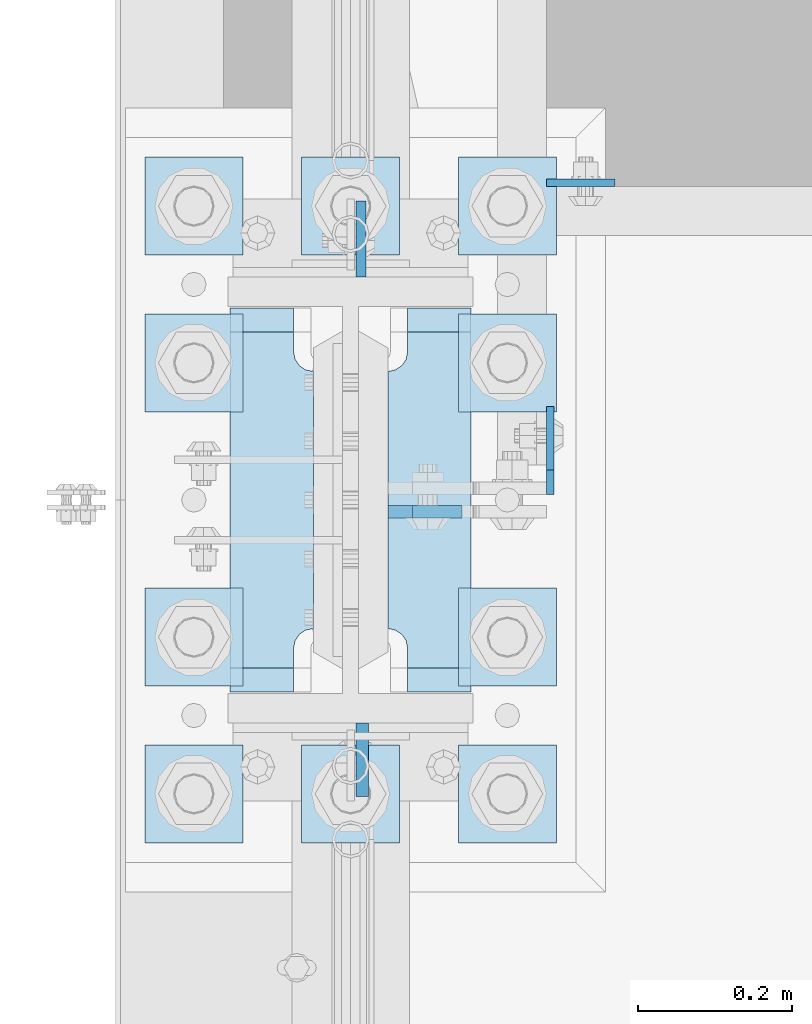
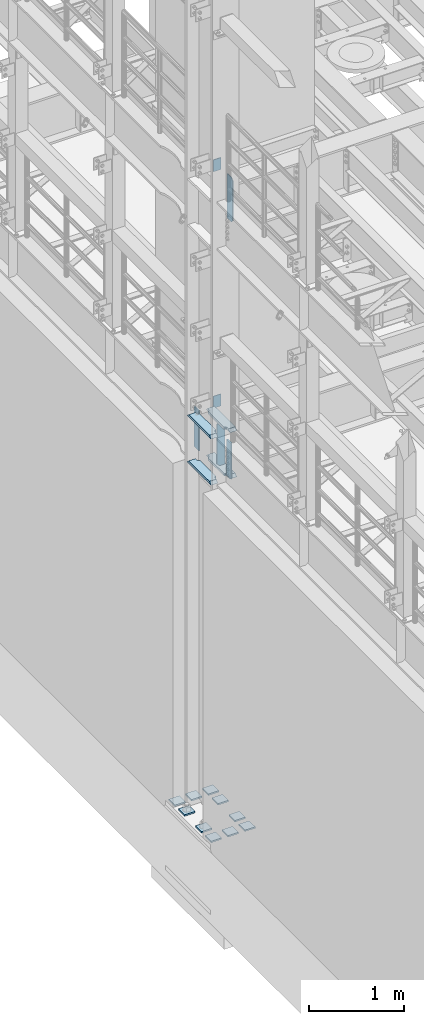
# One storey, part 1553 of 1876: 20 plates, 5 elements without a shape of their own.
"""IFC2X3 building model written with IfcOpenShell, lengths in millimetres."""

from ifc_helpers import new_model, si_unit, frame, origin_with_axes, place, context, subcontext, project, spatial, faceted_brep, material, type_object, element, aggregate, save


model = new_model("IFC2X3")

# Units and contexts
model_context = context("Model", 3, precision=1e-05, world=origin_with_axes())
body_context = subcontext(model_context, "Body", "Model", "MODEL_VIEW")
ifc_project = project(units=[si_unit("LENGTHUNIT", "METRE", prefix="MILLI"), si_unit("AREAUNIT", "SQUARE_METRE"), si_unit("VOLUMEUNIT", "CUBIC_METRE"), si_unit("MASSUNIT", "GRAM", prefix="KILO"), si_unit("TIMEUNIT", "SECOND"), si_unit("PLANEANGLEUNIT", "RADIAN"), si_unit("SOLIDANGLEUNIT", "STERADIAN"), si_unit("THERMODYNAMICTEMPERATUREUNIT", "DEGREE_CELSIUS"), si_unit("LUMINOUSINTENSITYUNIT", "LUMEN")], contexts=[model_context])

# Site, building, storey
site_placement = place(None, origin_with_axes())
site = spatial("IfcSite", under=ifc_project, at=site_placement, CompositionType="ELEMENT")
building_placement = place(site_placement, origin_with_axes())
building = spatial("IfcBuilding", under=site, at=building_placement, Name="Undefined", CompositionType="ELEMENT")
storey_placement = place(building_placement, origin_with_axes())
storey = spatial("IfcBuildingStorey", under=building, at=storey_placement, Name="Undefined", CompositionType="ELEMENT", Elevation=0.0)

# Assembly, plate
assembly_1_placement = place(storey_placement, origin_with_axes())
assembly_1 = element("IfcElementAssembly", 1, at=assembly_1_placement, inside=storey, Name="BEAM", AssemblyPlace="NOTDEFINED", PredefinedType="RIGID_FRAME")
ifc_material_1 = material(Name="STEEL/A36")
plate_type_1 = type_object("IfcPlateType", PredefinedType="NOTDEFINED")
plate_1_placement = place(assembly_1_placement, frame((254.0, 1935.1625, 8128.0), z_axis=(1.0, 0.0, 0.0), x_axis=(0.0, 0.0, -1.0)))
plate_1 = element("IfcPlate", 2, at=plate_1_placement, type_object=plate_type_1, material=ifc_material_1, Name="PLATE", context=body_context, shape_type="Brep", body=[
    faceted_brep([(0.0, -4.76249999999982, 0.0), (0.0, -4.76249999999982, 88.9000015258789), (0.0, 4.76249999999982, 88.9000015258789), (0.0, 4.76249999999982, 0.0), (152.399993896484, -4.76249999999982, 88.9000015258789), (152.399993896484, 4.76249999999982, 88.9000015258789), (152.399993896484, -4.76249999999982, 0.0), (152.399993896484, 4.76249999999982, 0.0)], [[[0, 1, 2, 3]], [[1, 4, 5, 2]], [[4, 6, 7, 5]], [[6, 0, 3, 7]], [[5, 7, 3, 2]], [[6, 4, 1, 0]]]),
])
aggregate(assembly_1, [plate_1])

assembly_2_placement = place(storey_placement, origin_with_axes())
assembly_2 = element("IfcElementAssembly", 3, at=assembly_2_placement, inside=storey, Name="BEAM", AssemblyPlace="NOTDEFINED", PredefinedType="RIGID_FRAME")
plate_2_placement = place(assembly_2_placement, frame((254.0, 1935.1625, 5105.4), z_axis=(1.0, 0.0, 0.0), x_axis=(0.0, 0.0, -1.0)))
plate_2 = element("IfcPlate", 4, at=plate_2_placement, type_object=plate_type_1, material=ifc_material_1, Name="PLATE", context=body_context, shape_type="Brep", body=[
    faceted_brep([(0.0, -4.76249999999982, 0.0), (0.0, -4.76249999999982, 88.9000015258789), (0.0, 4.76249999999982, 88.9000015258789), (0.0, 4.76249999999982, 0.0), (152.399993896484, -4.76249999999982, 88.9000015258789), (152.399993896484, 4.76249999999982, 88.9000015258789), (152.399993896484, -4.76249999999982, 0.0), (152.399993896484, 4.76249999999982, 0.0)], [[[0, 1, 2, 3]], [[1, 4, 5, 2]], [[4, 6, 7, 5]], [[6, 0, 3, 7]], [[5, 7, 3, 2]], [[6, 4, 1, 0]]]),
])
aggregate(assembly_2, [plate_2])

assembly_3_placement = place(storey_placement, origin_with_axes())
assembly_3 = element("IfcElementAssembly", 5, at=assembly_3_placement, inside=storey, Name="COLUMN", AssemblyPlace="NOTDEFINED", PredefinedType="RIGID_FRAME")
ifc_material_2 = material(Name="STEEL/A572-50")
plate_type_2 = type_object("IfcPlateType", PredefinedType="NOTDEFINED")
plate_3_placement = place(assembly_3_placement, frame((13.493000125885, 1812.925, 5076.825), z_axis=(0.0, 1.0, 0.0), x_axis=(0.0, 0.0, -1.0)))
plate_3 = element("IfcPlate", 6, at=plate_3_placement, type_object=plate_type_2, material=ifc_material_2, Name="PLATE", context=body_context, shape_type="Brep", body=[
    faceted_brep([(0.0, -6.35000000000036, 0.0), (0.0, -6.34999999999991, 98.4250030517578), (0.0, 6.34999999999991, 98.4250030517578), (0.0, 6.35000000000036, 0.0), (514.349975585938, -6.35000000000036, 98.4250030517578), (514.349975585938, 6.35000000000036, 98.4250030517578), (514.349975585938, -6.35000000000036, 0.0), (514.349975585938, 6.35000000000036, 0.0)], [[[0, 1, 2, 3]], [[1, 4, 5, 2]], [[4, 6, 7, 5]], [[6, 0, 3, 7]], [[5, 7, 3, 2]], [[6, 4, 1, 0]]]),
])

assembly_4_placement = place(storey_placement, origin_with_axes())
assembly_4 = element("IfcElementAssembly", 7, at=assembly_4_placement, inside=storey, Name="BEAM", AssemblyPlace="NOTDEFINED", PredefinedType="RIGID_FRAME")
plate_type_3 = type_object("IfcPlateType", PredefinedType="NOTDEFINED")
plate_4_placement = place(assembly_4_placement, frame((258.762999916077, 1531.14375, 7558.0875), z_axis=(0.0, 0.0, 1.0), x_axis=(0.0, 1.0, 0.0)))
plate_4 = element("IfcPlate", 8, at=plate_4_placement, type_object=plate_type_3, material=ifc_material_1, Name="PLATE", context=body_context, shape_type="Brep", body=[
    faceted_brep([(-9.76996261670138e-14, -4.76250000000073, 31.75), (0.0, -4.76249999999999, 538.162475585938), (0.0, 4.76249999999999, 538.162475585938), (-9.76996261670138e-14, 4.76250000000073, 31.75), (31.75, -4.76249999999999, 569.912475585938), (31.75, 4.76249999999999, 569.912475585938), (114.300003051758, -4.76249999999999, 569.912475585938), (114.300003051758, 4.76249999999999, 569.912475585938), (114.300003051758, -4.76249999999999, 0.0), (114.300003051758, 4.76249999999999, 0.0), (31.75, -4.76250000000073, 0.0), (31.75, 4.76250000000073, 0.0)], [[[0, 1, 2, 3]], [[1, 4, 5, 2]], [[4, 6, 7, 5]], [[6, 8, 9, 7]], [[8, 10, 11, 9]], [[10, 0, 3, 11]], [[5, 7, 9, 11, 3, 2]], [[10, 8, 6, 4, 1, 0]]]),
])
aggregate(assembly_4, [plate_4])

# Plate
plate_type_4 = type_object("IfcPlateType", PredefinedType="NOTDEFINED")
plate_5_placement = place(assembly_3_placement, frame((48.4187500000005, 1508.91949987411, 5099.05), z_axis=(1.0, 0.0, 0.0), x_axis=(0.0, 0.0, -1.0)))
plate_5 = element("IfcPlate", 9, at=plate_5_placement, type_object=plate_type_4, material=ifc_material_1, Name="PLATE", context=body_context, shape_type="Brep", body=[
    faceted_brep([(0.0, -7.93749999999998, 31.75), (0.0, -7.9375, 96.0437469482422), (0.0, 7.9375, 96.0437469482422), (0.0, 7.93749999999999, 31.75), (558.799987792969, -7.9375, 96.0437469482422), (558.799987792969, 7.9375, 96.0437469482422), (558.799987792969, -7.93749999999998, 31.75), (558.799987792969, 7.93749999999999, 31.75), (527.049987792969, -7.93749999999998, 0.0), (527.049987792969, 7.93749999999999, 0.0), (31.75, -7.93749999999998, 0.0), (31.75, 7.93749999999999, 0.0)], [[[0, 1, 2, 3]], [[1, 4, 5, 2]], [[4, 6, 7, 5]], [[6, 8, 9, 7]], [[8, 10, 11, 9]], [[10, 0, 3, 11]], [[5, 7, 9, 11, 3, 2]], [[10, 8, 6, 4, 1, 0]]]),
])

plate_6_placement = place(assembly_3_placement, frame((15.080500125885, 1235.075, 5067.3), z_axis=(0.0, -1.0, 0.0), x_axis=(0.0, 0.0, -1.0)))
plate_6 = element("IfcPlate", 10, at=plate_6_placement, type_object=plate_type_4, material=ifc_material_1, Name="PLATE", context=body_context, shape_type="Brep", body=[
    faceted_brep([(0.0, -7.9375, 0.0), (0.0, -7.9375, 95.25), (0.0, 7.9375, 95.25), (0.0, 7.9375, 0.0), (457.200012207031, -7.9375, 95.25), (457.200012207031, 7.9375, 95.25), (457.200012207031, -7.9375, 0.0), (457.200012207031, 7.9375, 0.0)], [[[0, 1, 2, 3]], [[1, 4, 5, 2]], [[4, 6, 7, 5]], [[6, 0, 3, 7]], [[5, 7, 3, 2]], [[6, 4, 1, 0]]]),
])

plate_type_5 = type_object("IfcPlateType", PredefinedType="NOTDEFINED")
plate_7_placement = place(assembly_3_placement, frame((-48.41875, 1274.7625, 4524.37501220703), z_axis=(0.0, 1.0, 0.0), x_axis=(-1.0, 0.0, 0.0)))
plate_7 = element("IfcPlate", 11, at=plate_7_placement, type_object=plate_type_5, material=ifc_material_2, Name="PLATE", context=body_context, shape_type="Brep", body=[
    faceted_brep([(107.949996948242, -15.875, 498.475006103516), (107.949996948242, 15.875, 467.025007631571), (25.3999996185303, 15.875, 467.025007631571), (25.3999996185303, -15.875, 498.475006103516), (23.4665397733561, -15.875, 431.604843634198), (25.3999996185303, -15.875, 441.325002670288), (25.3999996185303, 15.875, 441.325002670288), (23.4665397733561, 15.875, 431.604843634198), (17.9605119724001, -15.875, 423.36449069789), (17.9605119724001, 15.875, 423.36449069789), (9.72015903609281, -15.875, 417.858462896934), (9.72015903609281, 15.875, 417.858462896934), (0.0, -15.875, 415.925003051758), (0.0, 15.875, 415.925003051758), (0.0, -15.875, 82.5500030517578), (0.0, 15.875, 82.5500030517578), (9.72015903609099, -15.875, 80.616543206582), (9.72015903609099, 15.875, 80.616543206582), (17.9605119723983, -15.875, 75.1105154056258), (17.9605119723983, 15.875, 75.1105154056258), (23.4665397733552, -15.875, 66.8701624693183), (23.4665397733552, 15.875, 66.8701624693183), (25.3999996185303, -15.875, 57.1500034332275), (25.3999996185303, 15.875, 57.1500034332275), (25.3999996185303, 15.875, 31.449998471945), (25.3999996185303, -15.875, 0.0), (107.949996948242, 15.875, 31.449998471945), (107.949996948242, -15.875, 0.0)], [[[0, 1, 2, 3]], [[4, 5, 6, 7]], [[8, 4, 7, 9]], [[10, 8, 9, 11]], [[12, 10, 11, 13]], [[14, 12, 13, 15]], [[16, 14, 15, 17]], [[18, 16, 17, 19]], [[20, 18, 19, 21]], [[22, 20, 21, 23]], [[22, 23, 24, 25]], [[26, 27, 25, 24]], [[5, 4, 8, 10, 12, 14, 16, 18, 20, 22, 25, 27, 0, 3]], [[6, 5, 3, 2]], [[26, 24, 23, 21, 19, 17, 15, 13, 11, 9, 7, 6, 2, 1]], [[27, 26, 1, 0]]]),
])

plate_8_placement = place(assembly_3_placement, frame((-48.41875, 1274.7625, 5114.925), z_axis=(0.0, 1.0, 0.0), x_axis=(-1.0, 0.0, 0.0)))
plate_8 = element("IfcPlate", 12, at=plate_8_placement, type_object=plate_type_5, material=ifc_material_2, Name="PLATE", context=body_context, shape_type="Brep", body=[
    faceted_brep([(107.949996948242, -15.875, 498.475006103516), (107.949996948242, 15.875, 467.025007631571), (25.3999996185303, 15.875, 467.025007631571), (25.3999996185303, -15.875, 498.475006103516), (23.4665397733561, -15.875, 431.604843634198), (25.3999996185303, -15.875, 441.325002670288), (25.3999996185303, 15.875, 441.325002670288), (23.4665397733561, 15.875, 431.604843634198), (17.9605119724001, -15.875, 423.36449069789), (17.9605119724001, 15.875, 423.36449069789), (9.72015903609281, -15.875, 417.858462896934), (9.72015903609281, 15.875, 417.858462896934), (0.0, -15.875, 415.925003051758), (0.0, 15.875, 415.925003051758), (0.0, -15.875, 82.5500030517578), (0.0, 15.875, 82.5500030517578), (9.72015903609099, -15.875, 80.616543206582), (9.72015903609099, 15.875, 80.616543206582), (17.9605119723983, -15.875, 75.1105154056258), (17.9605119723983, 15.875, 75.1105154056258), (23.4665397733552, -15.875, 66.8701624693183), (23.4665397733552, 15.875, 66.8701624693183), (25.3999996185303, -15.875, 57.1500034332275), (25.3999996185303, 15.875, 57.1500034332275), (25.3999996185303, 15.875, 31.449998471945), (25.3999996185303, -15.875, 0.0), (107.949996948242, 15.875, 31.449998471945), (107.949996948242, -15.875, 0.0)], [[[0, 1, 2, 3]], [[4, 5, 6, 7]], [[8, 4, 7, 9]], [[10, 8, 9, 11]], [[12, 10, 11, 13]], [[14, 12, 13, 15]], [[16, 14, 15, 17]], [[18, 16, 17, 19]], [[20, 18, 19, 21]], [[22, 20, 21, 23]], [[22, 23, 24, 25]], [[26, 27, 25, 24]], [[5, 4, 8, 10, 12, 14, 16, 18, 20, 22, 25, 27, 0, 3]], [[6, 5, 3, 2]], [[26, 24, 23, 21, 19, 17, 15, 13, 11, 9, 7, 6, 2, 1]], [[27, 26, 1, 0]]]),
])

plate_9_placement = place(assembly_3_placement, frame((156.36875, 1274.7625, 4524.37501220703), z_axis=(0.0, 1.0, 0.0), x_axis=(-1.0, 0.0, 0.0)))
plate_9 = element("IfcPlate", 13, at=plate_9_placement, type_object=plate_type_5, material=ifc_material_2, Name="PLATE", context=body_context, shape_type="Brep", body=[
    faceted_brep([(82.5499973297119, -15.875, 498.475006103516), (82.5499973297119, 15.875, 467.025007631571), (0.0, 15.875, 467.025007631571), (0.0, -15.875, 498.475006103516), (82.5499973297119, 15.875, 31.449998471945), (82.5499973297119, -15.875, 0.0), (0.0, -15.875, 0.0), (0.0, 15.875, 31.449998471945), (82.5499973297119, 15.875, 57.1500034332275), (82.5499973297119, -15.875, 57.1500034332275), (84.4834571748879, -15.875, 66.8701624693188), (84.4834571748879, 15.875, 66.8701624693188), (89.9894849758439, -15.875, 75.1105154056261), (89.9894849758439, 15.875, 75.1105154056261), (98.2298379121512, -15.875, 80.616543206582), (98.2298379121512, 15.875, 80.616543206582), (107.949996948242, -15.875, 82.5500030517578), (107.949996948242, 15.875, 82.5500030517578), (107.949996948242, -15.875, 415.925003051758), (107.949996948242, 15.875, 415.925003051758), (98.2298379121512, -15.875, 417.858462896934), (98.2298379121512, 15.875, 417.858462896934), (89.9894849758439, -15.875, 423.36449069789), (89.9894849758439, 15.875, 423.36449069789), (84.483457174887, -15.875, 431.604843634197), (84.483457174887, 15.875, 431.604843634197), (82.5499973297119, -15.875, 441.325002670288), (82.5499973297119, 15.875, 441.325002670288)], [[[0, 1, 2, 3]], [[4, 5, 6, 7]], [[8, 9, 5, 4]], [[10, 9, 8, 11]], [[12, 10, 11, 13]], [[14, 12, 13, 15]], [[16, 14, 15, 17]], [[18, 16, 17, 19]], [[20, 18, 19, 21]], [[22, 20, 21, 23]], [[24, 22, 23, 25]], [[26, 24, 25, 27]], [[6, 5, 9, 10, 12, 14, 16, 18, 20, 22, 24, 26, 0, 3]], [[7, 6, 3, 2]], [[27, 25, 23, 21, 19, 17, 15, 13, 11, 8, 4, 7, 2, 1]], [[26, 27, 1, 0]]]),
])

plate_10_placement = place(assembly_3_placement, frame((156.36875, 1274.7625, 5114.925), z_axis=(0.0, 1.0, 0.0), x_axis=(-1.0, 0.0, 0.0)))
plate_10 = element("IfcPlate", 14, at=plate_10_placement, type_object=plate_type_5, material=ifc_material_2, Name="PLATE", context=body_context, shape_type="Brep", body=[
    faceted_brep([(82.5499973297119, -15.875, 498.475006103516), (82.5499973297119, 15.875, 467.025007631571), (0.0, 15.875, 467.025007631571), (0.0, -15.875, 498.475006103516), (82.5499973297119, 15.875, 31.449998471945), (82.5499973297119, -15.875, 0.0), (0.0, -15.875, 0.0), (0.0, 15.875, 31.449998471945), (82.5499973297119, 15.875, 57.1500034332275), (82.5499973297119, -15.875, 57.1500034332275), (84.4834571748879, -15.875, 66.8701624693188), (84.4834571748879, 15.875, 66.8701624693188), (89.9894849758439, -15.875, 75.1105154056261), (89.9894849758439, 15.875, 75.1105154056261), (98.2298379121512, -15.875, 80.616543206582), (98.2298379121512, 15.875, 80.616543206582), (107.949996948242, -15.875, 82.5500030517578), (107.949996948242, 15.875, 82.5500030517578), (107.949996948242, -15.875, 415.925003051758), (107.949996948242, 15.875, 415.925003051758), (98.2298379121512, -15.875, 417.858462896934), (98.2298379121512, 15.875, 417.858462896934), (89.9894849758439, -15.875, 423.36449069789), (89.9894849758439, 15.875, 423.36449069789), (84.483457174887, -15.875, 431.604843634197), (84.483457174887, 15.875, 431.604843634197), (82.5499973297119, -15.875, 441.325002670288), (82.5499973297119, 15.875, 441.325002670288)], [[[0, 1, 2, 3]], [[4, 5, 6, 7]], [[8, 9, 5, 4]], [[10, 9, 8, 11]], [[12, 10, 11, 13]], [[14, 12, 13, 15]], [[16, 14, 15, 17]], [[18, 16, 17, 19]], [[20, 18, 19, 21]], [[22, 20, 21, 23]], [[24, 22, 23, 25]], [[26, 24, 25, 27]], [[6, 5, 9, 10, 12, 14, 16, 18, 20, 22, 24, 26, 0, 3]], [[7, 6, 3, 2]], [[27, 25, 23, 21, 19, 17, 15, 13, 11, 8, 4, 7, 2, 1]], [[26, 27, 1, 0]]]),
])

aggregate(assembly_3, [plate_7, plate_8, plate_9, plate_10, plate_5, plate_3, plate_6])

# Assembly, plates
assembly_5_placement = place(storey_placement, origin_with_axes())
assembly_5 = element("IfcElementAssembly", 15, at=assembly_5_placement, inside=storey, Name="TEMPLATE", AssemblyPlace="NOTDEFINED", PredefinedType="RIGID_FRAME")
plate_type_6 = type_object("IfcPlateType", PredefinedType="NOTDEFINED")
plate_11_placement = place(assembly_5_placement, frame((-139.7, 1206.5, 104.775), z_axis=(-1.0, 0.0, 0.0), x_axis=(0.0, -1.0, 0.0)))
plate_11 = element("IfcPlate", 16, at=plate_11_placement, type_object=plate_type_6, material=ifc_material_2, Name="PLATE WASHER", context=body_context, shape_type="Brep", body=[
    faceted_brep([(-9.09494701772928e-13, -9.525, -1.81898940354586e-12), (0.0, -9.52500000000001, 127.0), (0.0, 9.52500000000001, 127.0), (-9.09494701772928e-13, 9.525, -1.81898940354586e-12), (127.0, -9.52500000000001, 127.0), (127.0, 9.52500000000001, 127.0), (127.0, -9.52500000000001, 0.0), (127.0, 9.52500000000001, 0.0)], [[[0, 1, 2, 3]], [[1, 4, 5, 2]], [[4, 6, 7, 5]], [[6, 0, 3, 7]], [[5, 7, 3, 2]], [[6, 4, 1, 0]]]),
])
plate_12_placement = place(assembly_5_placement, frame((63.5, 1206.5, 104.775), z_axis=(-1.0, 0.0, 0.0), x_axis=(0.0, -1.0, 0.0)))
plate_12 = element("IfcPlate", 17, at=plate_12_placement, type_object=plate_type_6, material=ifc_material_2, Name="PLATE WASHER", context=body_context, shape_type="Brep", body=[
    faceted_brep([(-9.09494701772928e-13, -9.525, -1.81898940354586e-12), (0.0, -9.52500000000001, 127.0), (0.0, 9.52500000000001, 127.0), (-9.09494701772928e-13, 9.525, -1.81898940354586e-12), (127.0, -9.52500000000001, 127.0), (127.0, 9.52500000000001, 127.0), (127.0, -9.52500000000001, 0.0), (127.0, 9.52500000000001, 0.0)], [[[0, 1, 2, 3]], [[1, 4, 5, 2]], [[4, 6, 7, 5]], [[6, 0, 3, 7]], [[5, 7, 3, 2]], [[6, 4, 1, 0]]]),
])
plate_13_placement = place(assembly_5_placement, frame((266.7, 1206.5, 104.775), z_axis=(-1.0, 0.0, 0.0), x_axis=(0.0, -1.0, 0.0)))
plate_13 = element("IfcPlate", 18, at=plate_13_placement, type_object=plate_type_6, material=ifc_material_2, Name="PLATE WASHER", context=body_context, shape_type="Brep", body=[
    faceted_brep([(-9.09494701772928e-13, -9.525, -1.81898940354586e-12), (0.0, -9.52500000000001, 127.0), (0.0, 9.52500000000001, 127.0), (-9.09494701772928e-13, 9.525, -1.81898940354586e-12), (127.0, -9.52500000000001, 127.0), (127.0, 9.52500000000001, 127.0), (127.0, -9.52500000000001, 0.0), (127.0, 9.52500000000001, 0.0)], [[[0, 1, 2, 3]], [[1, 4, 5, 2]], [[4, 6, 7, 5]], [[6, 0, 3, 7]], [[5, 7, 3, 2]], [[6, 4, 1, 0]]]),
])
plate_14_placement = place(assembly_5_placement, frame((-139.7, 1409.7, 104.775), z_axis=(-1.0, 0.0, 0.0), x_axis=(0.0, -1.0, 0.0)))
plate_14 = element("IfcPlate", 19, at=plate_14_placement, type_object=plate_type_6, material=ifc_material_2, Name="PLATE WASHER", context=body_context, shape_type="Brep", body=[
    faceted_brep([(-9.09494701772928e-13, -9.525, -1.81898940354586e-12), (0.0, -9.52500000000001, 127.0), (0.0, 9.52500000000001, 127.0), (-9.09494701772928e-13, 9.525, -1.81898940354586e-12), (127.0, -9.52500000000001, 127.0), (127.0, 9.52500000000001, 127.0), (127.0, -9.52500000000001, 0.0), (127.0, 9.52500000000001, 0.0)], [[[0, 1, 2, 3]], [[1, 4, 5, 2]], [[4, 6, 7, 5]], [[6, 0, 3, 7]], [[5, 7, 3, 2]], [[6, 4, 1, 0]]]),
])
plate_15_placement = place(assembly_5_placement, frame((266.7, 1409.7, 104.775), z_axis=(-1.0, 0.0, 0.0), x_axis=(0.0, -1.0, 0.0)))
plate_15 = element("IfcPlate", 20, at=plate_15_placement, type_object=plate_type_6, material=ifc_material_2, Name="PLATE WASHER", context=body_context, shape_type="Brep", body=[
    faceted_brep([(-9.09494701772928e-13, -9.525, -1.81898940354586e-12), (0.0, -9.52500000000001, 127.0), (0.0, 9.52500000000001, 127.0), (-9.09494701772928e-13, 9.525, -1.81898940354586e-12), (127.0, -9.52500000000001, 127.0), (127.0, 9.52500000000001, 127.0), (127.0, -9.52500000000001, 0.0), (127.0, 9.52500000000001, 0.0)], [[[0, 1, 2, 3]], [[1, 4, 5, 2]], [[4, 6, 7, 5]], [[6, 0, 3, 7]], [[5, 7, 3, 2]], [[6, 4, 1, 0]]]),
])
plate_16_placement = place(assembly_5_placement, frame((-139.7, 1765.3, 104.775), z_axis=(-1.0, 0.0, 0.0), x_axis=(0.0, -1.0, 0.0)))
plate_16 = element("IfcPlate", 21, at=plate_16_placement, type_object=plate_type_6, material=ifc_material_2, Name="PLATE WASHER", context=body_context, shape_type="Brep", body=[
    faceted_brep([(-9.09494701772928e-13, -9.525, -1.81898940354586e-12), (0.0, -9.52500000000001, 127.0), (0.0, 9.52500000000001, 127.0), (-9.09494701772928e-13, 9.525, -1.81898940354586e-12), (127.0, -9.52500000000001, 127.0), (127.0, 9.52500000000001, 127.0), (127.0, -9.52500000000001, 0.0), (127.0, 9.52500000000001, 0.0)], [[[0, 1, 2, 3]], [[1, 4, 5, 2]], [[4, 6, 7, 5]], [[6, 0, 3, 7]], [[5, 7, 3, 2]], [[6, 4, 1, 0]]]),
])
plate_17_placement = place(assembly_5_placement, frame((266.7, 1765.3, 104.775), z_axis=(-1.0, 0.0, 0.0), x_axis=(0.0, -1.0, 0.0)))
plate_17 = element("IfcPlate", 22, at=plate_17_placement, type_object=plate_type_6, material=ifc_material_2, Name="PLATE WASHER", context=body_context, shape_type="Brep", body=[
    faceted_brep([(-9.09494701772928e-13, -9.525, -1.81898940354586e-12), (0.0, -9.52500000000001, 127.0), (0.0, 9.52500000000001, 127.0), (-9.09494701772928e-13, 9.525, -1.81898940354586e-12), (127.0, -9.52500000000001, 127.0), (127.0, 9.52500000000001, 127.0), (127.0, -9.52500000000001, 0.0), (127.0, 9.52500000000001, 0.0)], [[[0, 1, 2, 3]], [[1, 4, 5, 2]], [[4, 6, 7, 5]], [[6, 0, 3, 7]], [[5, 7, 3, 2]], [[6, 4, 1, 0]]]),
])
plate_18_placement = place(assembly_5_placement, frame((-139.7, 1968.5, 104.775), z_axis=(-1.0, 0.0, 0.0), x_axis=(0.0, -1.0, 0.0)))
plate_18 = element("IfcPlate", 23, at=plate_18_placement, type_object=plate_type_6, material=ifc_material_2, Name="PLATE WASHER", context=body_context, shape_type="Brep", body=[
    faceted_brep([(-9.09494701772928e-13, -9.525, -1.81898940354586e-12), (0.0, -9.52500000000001, 127.0), (0.0, 9.52500000000001, 127.0), (-9.09494701772928e-13, 9.525, -1.81898940354586e-12), (127.0, -9.52500000000001, 127.0), (127.0, 9.52500000000001, 127.0), (127.0, -9.52500000000001, 0.0), (127.0, 9.52500000000001, 0.0)], [[[0, 1, 2, 3]], [[1, 4, 5, 2]], [[4, 6, 7, 5]], [[6, 0, 3, 7]], [[5, 7, 3, 2]], [[6, 4, 1, 0]]]),
])
plate_19_placement = place(assembly_5_placement, frame((63.5, 1968.5, 104.775), z_axis=(-1.0, 0.0, 0.0), x_axis=(0.0, -1.0, 0.0)))
plate_19 = element("IfcPlate", 24, at=plate_19_placement, type_object=plate_type_6, material=ifc_material_2, Name="PLATE WASHER", context=body_context, shape_type="Brep", body=[
    faceted_brep([(-9.09494701772928e-13, -9.525, -1.81898940354586e-12), (0.0, -9.52500000000001, 127.0), (0.0, 9.52500000000001, 127.0), (-9.09494701772928e-13, 9.525, -1.81898940354586e-12), (127.0, -9.52500000000001, 127.0), (127.0, 9.52500000000001, 127.0), (127.0, -9.52500000000001, 0.0), (127.0, 9.52500000000001, 0.0)], [[[0, 1, 2, 3]], [[1, 4, 5, 2]], [[4, 6, 7, 5]], [[6, 0, 3, 7]], [[5, 7, 3, 2]], [[6, 4, 1, 0]]]),
])
plate_20_placement = place(assembly_5_placement, frame((266.7, 1968.5, 104.775), z_axis=(-1.0, 0.0, 0.0), x_axis=(0.0, -1.0, 0.0)))
plate_20 = element("IfcPlate", 25, at=plate_20_placement, type_object=plate_type_6, material=ifc_material_2, Name="PLATE WASHER", context=body_context, shape_type="Brep", body=[
    faceted_brep([(-9.09494701772928e-13, -9.525, -1.81898940354586e-12), (0.0, -9.52500000000001, 127.0), (0.0, 9.52500000000001, 127.0), (-9.09494701772928e-13, 9.525, -1.81898940354586e-12), (127.0, -9.52500000000001, 127.0), (127.0, 9.52500000000001, 127.0), (127.0, -9.52500000000001, 0.0), (127.0, 9.52500000000001, 0.0)], [[[0, 1, 2, 3]], [[1, 4, 5, 2]], [[4, 6, 7, 5]], [[6, 0, 3, 7]], [[5, 7, 3, 2]], [[6, 4, 1, 0]]]),
])
aggregate(assembly_5, [plate_11, plate_12, plate_13, plate_14, plate_15, plate_16, plate_17, plate_18, plate_19, plate_20])

save(model, "model.ifc")
